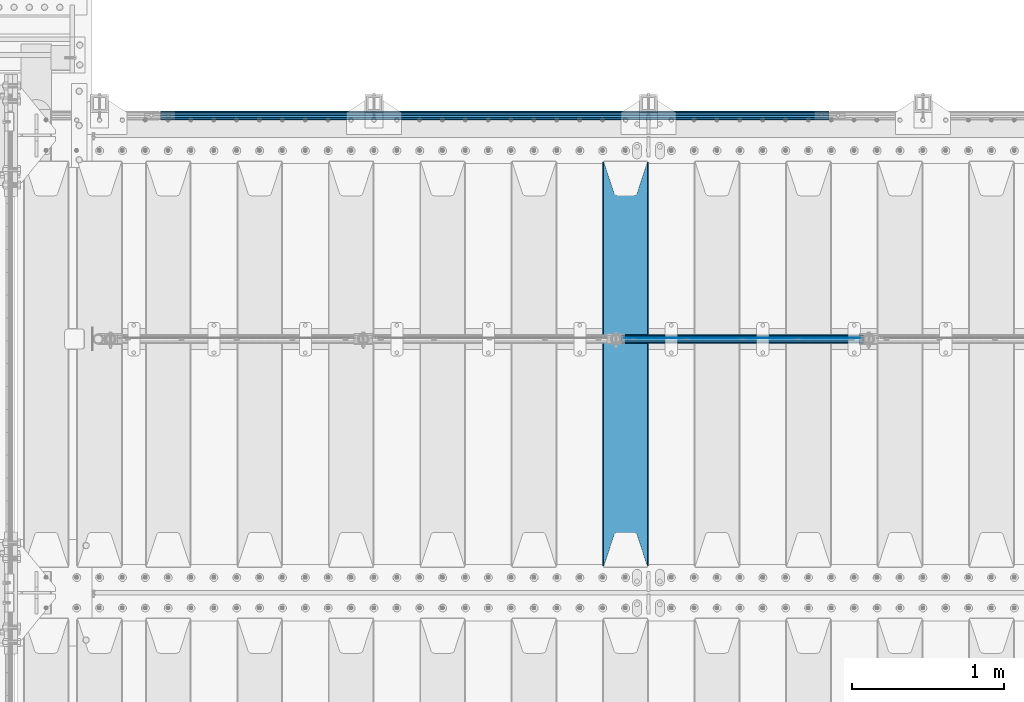
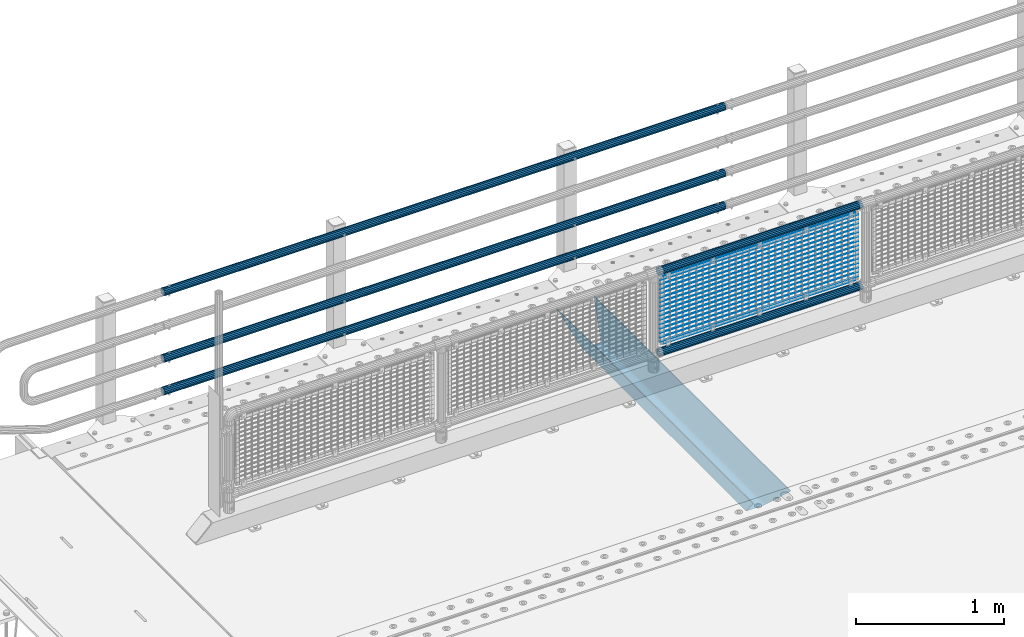
# One storey, part 111 of 219: 23 beams.
"""IFC2X3 building model written with IfcOpenShell, lengths in millimetres."""

import ifcopenshell
import ifcopenshell.guid

model = None  # the IFC model being written
_history = None  # IfcOwnerHistory: only IFC2X3 demands one
_inside = {}  # id of a spatial element -> (the spatial element, [elements in it])
_under = {}  # id of a project, library or spatial element -> (it, [spatial elements below it])
_declared = {}  # id of a project -> (the project, [libraries it declares])
_typed = {}  # id of a type object -> (the type object, [elements of that type])
_made_of = {}  # id of a material, layer set ... -> (it, [elements and type objects made of it])


def new_model(schema):
    """Start an empty IFC model of exactly this schema.

    Asked for "IFC4X3", IfcOpenShell would pick the latest addendum, in which some entities
    have other attributes; the version numbers below select the first issue.
    IFC2X3 requires an IfcOwnerHistory on every rooted entity: one is made here for all.
    """
    global model, _history
    if schema == "IFC4X3":
        model = ifcopenshell.file(schema_version=(4, 3, 0, 0))
    else:
        model = ifcopenshell.file(schema=schema)
    _inside.clear()
    _under.clear()
    _declared.clear()
    _typed.clear()
    _made_of.clear()
    _history = None
    if model.schema == "IFC2X3":
        org = make("IfcOrganization", Name="unknown")
        user = make(
            "IfcPersonAndOrganization",
            ThePerson=make("IfcPerson", FamilyName="unknown"),
            TheOrganization=org,
        )
        app = make(
            "IfcApplication",
            ApplicationDeveloper=org,
            Version="unknown",
            ApplicationFullName="unknown",
            ApplicationIdentifier="unknown",
        )
        _history = make(
            "IfcOwnerHistory",
            OwningUser=user,
            OwningApplication=app,
            ChangeAction="ADDED",
            CreationDate=0,
        )
    return model


def make(cls, **values):
    """One entity of the class cls with the attributes given. An attribute that is None is left unset."""
    return model.create_entity(
        cls, **{name: value for name, value in values.items() if value is not None}
    )


def rooted(cls, **values):
    """An entity with a GlobalId (a new one), such as an element, a storey or a relation."""
    return make(cls, GlobalId=ifcopenshell.guid.new(), OwnerHistory=_history, **values)


def si_unit(unit_type, name, prefix=None):
    """IfcSIUnit, for example si_unit("LENGTHUNIT", "METRE", prefix="MILLI")."""
    return make("IfcSIUnit", UnitType=unit_type, Prefix=prefix, Name=name)


def assignment(units):
    """IfcUnitAssignment: the units of a project."""
    return None if units is None else make("IfcUnitAssignment", Units=units)


def point(xyz):
    """IfcCartesianPoint."""
    return None if xyz is None else make("IfcCartesianPoint", Coordinates=xyz)


def direction(xyz):
    """IfcDirection."""
    return None if xyz is None else make("IfcDirection", DirectionRatios=xyz)


def frame(location, z_axis=None, x_axis=None):
    """IfcAxis2Placement3D, a coordinate frame: its origin and axes. An axis left out is left unset."""
    return make(
        "IfcAxis2Placement3D",
        Location=point(location),
        Axis=direction(z_axis),
        RefDirection=direction(x_axis),
    )


def origin_with_axes():
    """The frame at (0, 0, 0) with the z axis (0, 0, 1) and the x axis (1, 0, 0) written out."""
    return frame((0.0, 0.0, 0.0), z_axis=(0.0, 0.0, 1.0), x_axis=(1.0, 0.0, 0.0))


def place(relative_to, where):
    """IfcLocalPlacement: puts the frame where relative to a parent placement (None: the world)."""
    return make(
        "IfcLocalPlacement", PlacementRelTo=relative_to, RelativePlacement=where
    )


def context(
    kind, dimensions, precision=None, world=None, true_north=None, identifier=None
):
    """IfcGeometricRepresentationContext, for example the 3D "Model" context."""
    return make(
        "IfcGeometricRepresentationContext",
        ContextIdentifier=identifier,
        ContextType=kind,
        CoordinateSpaceDimension=dimensions,
        Precision=precision,
        WorldCoordinateSystem=world,
        TrueNorth=true_north,
    )


def subcontext(parent, identifier, kind, view, scale=None):
    """IfcGeometricRepresentationSubContext, for example "Body" below "Model"."""
    return make(
        "IfcGeometricRepresentationSubContext",
        ContextIdentifier=identifier,
        ContextType=kind,
        ParentContext=parent,
        TargetScale=scale,
        TargetView=view,
    )


def project(units=None, contexts=None):
    """IfcProject with its units and contexts."""
    return rooted(
        "IfcProject",
        Name="project",
        RepresentationContexts=contexts,
        UnitsInContext=assignment(units),
    )


def spatial(cls, under=None, at=None, **own):
    """A site, building, storey or space (cls), placed at a placement, below another one or the project."""
    s = rooted(cls, ObjectPlacement=at, **own)
    if under is not None:
        _under.setdefault(under.id(), (under, []))[1].append(s)
    return s


def faces_of(points, faces, orient=None, outer=None):
    """IfcFace entities. A face is a list of loops; a loop is a list of indices into points, from 0.

    orient and outer hold one flag for each loop. By default every Orientation is true, the
    first loop of a face is its IfcFaceOuterBound and the others are IfcFaceBound.
    """
    made = []
    for i, loops in enumerate(faces):
        bounds = []
        for j, loop in enumerate(loops):
            is_outer = j == 0 if outer is None else outer[i][j]
            bounds.append(
                make(
                    "IfcFaceOuterBound" if is_outer else "IfcFaceBound",
                    Bound=make("IfcPolyLoop", Polygon=[points[k] for k in loop]),
                    Orientation=True if orient is None else orient[i][j],
                )
            )
        made.append(make("IfcFace", Bounds=bounds))
    return made


def faceted_brep(points, faces, orient=None, outer=None, voids=None):
    """IfcFacetedBrep: a solid bounded by flat faces; with voids (closed shells), ...WithVoids."""
    shared = [point(p) for p in points]
    hull = make("IfcClosedShell", CfsFaces=faces_of(shared, faces, orient, outer))
    if voids is None:
        return make("IfcFacetedBrep", Outer=hull)
    return make(
        "IfcFacetedBrepWithVoids",
        Outer=hull,
        Voids=[
            make(cls, CfsFaces=faces_of(shared, fs, o, b)) for cls, fs, o, b in voids
        ],
    )


def shape(context_of_items, identifier, shape_type, items):
    """IfcShapeRepresentation: the items that make up one representation, for example the "Body"."""
    return make(
        "IfcShapeRepresentation",
        ContextOfItems=context_of_items,
        RepresentationIdentifier=identifier,
        RepresentationType=shape_type,
        Items=items,
    )


def material(Name=None, Category=None):
    """IfcMaterial."""
    return make("IfcMaterial", Name=Name, Category=Category)


def made_of(thing, what):
    """Note that an element or type object is made of a material, layer set ...; save() writes the relation."""
    if what is not None:
        _made_of.setdefault(what.id(), (what, []))[1].append(thing)
    return thing


def type_object(cls, material=None, **own):
    """A type object (cls), such as IfcWallType, which elements share."""
    return made_of(rooted(cls, **own), material)


def element(
    cls,
    number,
    at=None,
    inside=None,
    cuts=None,
    type_object=None,
    material=None,
    context=None,
    identifier="Body",
    shape_type=None,
    held_by="IfcProductDefinitionShape",
    body=None,
    shapes=None,
    **own,
):
    """One element of the class cls, such as IfcWall. Its Tag is "e" and its number.

    at: its placement. inside: the storey or other place that contains it. cuts: it is an
    opening in that element (IfcRelVoidsElement). A single representation is given by context,
    identifier, shape_type and body (its items); several are given by shapes. held_by: the class
    of the entity that holds the representations. save() writes the other relations.
    """
    e = rooted(cls, Tag="e%d" % number, ObjectPlacement=at, **own)
    if body is not None:
        shapes = [shape(context, identifier, shape_type, body)]
    if shapes is not None:
        e.Representation = make(held_by, Representations=shapes)
    if inside is not None:
        _inside.setdefault(inside.id(), (inside, []))[1].append(e)
    if cuts is not None:
        rooted(
            "IfcRelVoidsElement", RelatingBuildingElement=cuts, RelatedOpeningElement=e
        )
    if type_object is not None:
        _typed.setdefault(type_object.id(), (type_object, []))[1].append(e)
    return made_of(e, material)


def aggregate(whole, parts):
    """IfcRelAggregates: a whole, such as a stair, and the parts it consists of."""
    return rooted("IfcRelAggregates", RelatingObject=whole, RelatedObjects=parts)


def save(model, path):
    """Write the relations noted so far, then the file.

    IfcRelAggregates (storeys below a building ...), IfcRelContainedInSpatialStructure (elements
    in a storey), IfcRelDefinesByType, IfcRelAssociatesMaterial and IfcRelDeclares: one each for
    every whole, place, type object, material and project.
    """
    for whole, parts in _under.values():
        aggregate(whole, parts)
    for where, things in _inside.values():
        rooted(
            "IfcRelContainedInSpatialStructure",
            RelatedElements=things,
            RelatingStructure=where,
        )
    for kind, things in _typed.values():
        rooted("IfcRelDefinesByType", RelatedObjects=things, RelatingType=kind)
    for what, things in _made_of.values():
        rooted("IfcRelAssociatesMaterial", RelatedObjects=things, RelatingMaterial=what)
    for by, libraries in _declared.values():
        rooted("IfcRelDeclares", RelatingContext=by, RelatedDefinitions=libraries)
    model.write(path)


model = new_model("IFC2X3")

# Units and contexts
model_context = context("Model", 3, precision=1e-05, world=origin_with_axes())
body_context = subcontext(model_context, "Body", "Model", "MODEL_VIEW")
ifc_project = project(units=[si_unit("LENGTHUNIT", "METRE", prefix="MILLI"), si_unit("AREAUNIT", "SQUARE_METRE"), si_unit("VOLUMEUNIT", "CUBIC_METRE"), si_unit("MASSUNIT", "GRAM", prefix="KILO"), si_unit("TIMEUNIT", "SECOND"), si_unit("PLANEANGLEUNIT", "RADIAN"), si_unit("SOLIDANGLEUNIT", "STERADIAN"), si_unit("THERMODYNAMICTEMPERATUREUNIT", "DEGREE_CELSIUS"), si_unit("LUMINOUSINTENSITYUNIT", "LUMEN")], contexts=[model_context])

# Site, building, storey
site_placement = place(None, origin_with_axes())
site = spatial("IfcSite", under=ifc_project, at=site_placement, CompositionType="ELEMENT")
building_placement = place(site_placement, origin_with_axes())
building = spatial("IfcBuilding", under=site, at=building_placement, Name="Standard", CompositionType="ELEMENT")
storey_placement = place(building_placement, origin_with_axes())
storey = spatial("IfcBuildingStorey", under=building, at=storey_placement, Name="Undefined", CompositionType="ELEMENT", Elevation=0.0)

# Beams
ifc_material_1 = material(Name="STEEL/S355N")
beam_type_1 = type_object("IfcBeamType", PredefinedType="NOTDEFINED")
beam_1_placement = place(storey_placement, frame((4000.0, 30175.0, -115.0), z_axis=(0.0, 0.0, 1.0), x_axis=(0.0, 1.0, 0.0)))
element("IfcBeam", 1, at=beam_1_placement, inside=storey, type_object=beam_type_1, material=ifc_material_1, context=body_context, shape_type="Brep", body=[
    faceted_brep([(0.0, 150.0, 115.0), (0.0, 143.690000000001, 115.0), (2650.00000000297, 143.690000000001, 115.0), (2650.00000000297, 150.0, 115.0), (2650.00000000297, 142.0595652184, 110.000000003094), (2650.00000000297, 148.3695652184, 110.000000003094), (2441.90079219209, -80.110360073113, -98.0992078077845), (2437.7588105432, -77.5672621345566, -102.241189456673), (2434.06523489747, -74.4080125315541, -105.934765102404), (2430.9108609509, -70.7102721255742, -109.089139048974), (2428.37322971128, -66.5649389910068, -111.626770288588), (2426.51472138055, -62.0739139532889, -113.485278619323), (2425.38102192092, -57.3475956567672, -114.618978078955), (2424.99999999988, -52.5021667386536, -115.0), (2424.99999999988, 52.5021667386536, -115.0), (2425.38102192092, 57.3475956567672, -114.618978078955), (2426.51472138055, 62.0739139532889, -113.485278619323), (2428.37322971128, 66.5649389910068, -111.626770288588), (2430.9108609509, 70.7102721255742, -109.089139048974), (2434.06523489747, 74.4080125315541, -105.934765102404), (2437.7588105432, 77.5672621345566, -102.241189456673), (2441.90079219209, 80.110360073113, -98.0992078077846), (2446.38936140512, 81.9747917625791, -93.6106385947584), (2448.2494850041, 76.2713538057269, -91.7505149957729), (2444.62967112263, 74.7677798626082, -95.3703288772456), (2441.28936334127, 72.7168944282894, -98.710636658607), (2438.31067330439, 70.1691124903828, -101.689326695487), (2435.76682334748, 67.1870637758839, -104.233176652398), (2433.72034654134, 63.8440531834913, -106.279653458539), (2432.22154950042, 60.2222587982342, -107.778450499454), (2431.30727574265, 56.4107117849107, -108.692724257221), (2430.99999999987, 52.5031078186894, -109.0), (2430.99999999987, -52.5031078186894, -109.0), (2431.30727574265, -56.4107117849107, -108.692724257221), (2432.22154950042, -60.2222587982342, -107.778450499454), (2433.72034654134, -63.8440531834913, -106.279653458539), (2435.76682334748, -67.1870637758839, -104.233176652398), (2438.31067330439, -70.1691124903828, -101.689326695487), (2441.28936334127, -72.7168944282894, -98.7106366586071), (2444.62967112263, -74.7677798626082, -95.3703288772457), (2448.2494850041, -76.2713538057269, -91.7505149957729), (2650.00000000297, -142.0595652184, 110.000000003094), (2650.00000000297, -148.3695652184, 110.000000003094), (2446.38936140512, -81.9747917625791, -93.6106385947584), (2650.00000000297, -143.690000000001, 115.0), (2650.00000000297, -150.0, 115.0), (0.0, -143.690000000001, 115.0), (0.0, -150.0, 115.0), (0.0, -148.369565218261, 110.000000002667), (203.610638597427, -81.9747917625791, -93.6106385947584), (208.09920781045, -80.110360073113, -98.0992078077845), (212.241189459342, -77.5672621345566, -102.241189456673), (215.93476510507, -74.4080125315541, -105.934765102404), (219.089139051641, -70.7102721255742, -109.089139048974), (221.626770291256, -66.5649389910068, -111.626770288588), (223.485278621989, -62.0739139532889, -113.485278619323), (224.618978081624, -57.3475956567672, -114.618978078955), (225.000000002663, -52.5021667386536, -115.0), (225.000000002663, 52.5021667386536, -115.0), (224.618978081624, 57.3475956567672, -114.618978078955), (223.485278621989, 62.0739139532889, -113.485278619323), (221.626770291256, 66.5649389910068, -111.626770288588), (219.089139051641, 70.7102721255742, -109.089139048974), (215.93476510507, 74.4080125315541, -105.934765102404), (212.241189459342, 77.5672621345566, -102.241189456673), (208.09920781045, 80.110360073113, -98.0992078077846), (203.610638597427, 81.9747917625791, -93.6106385947584), (0.0, 148.369565218261, 110.000000002667), (0.0, 142.059565218262, 110.000000002667), (201.750514998439, 76.2713538057269, -91.7505149957729), (205.370328879915, 74.7677798626082, -95.3703288772456), (208.710636661275, 72.7168944282894, -98.710636658607), (211.689326698157, 70.1691124903828, -101.689326695487), (214.233176655063, 67.1870637758839, -104.233176652398), (216.279653461206, 63.8440531834913, -106.279653458539), (217.778450502123, 60.2222587982342, -107.778450499454), (218.69272425989, 56.4107117849107, -108.692724257221), (219.00000000267, 52.5031078186894, -109.0), (219.00000000267, -52.5031078186894, -109.0), (218.69272425989, -56.4107117849107, -108.692724257221), (217.778450502123, -60.2222587982342, -107.778450499454), (216.279653461206, -63.8440531834913, -106.279653458539), (214.233176655063, -67.1870637758839, -104.233176652398), (211.689326698157, -70.1691124903828, -101.689326695487), (208.710636661275, -72.7168944282894, -98.7106366586071), (205.370328879915, -74.7677798626082, -95.3703288772457), (201.750514998439, -76.2713538057269, -91.7505149957729), (0.0, -142.059565218262, 110.000000002667)], [[[0, 1, 2, 3]], [[3, 2, 4, 5]], [[6, 7, 8, 9, 10, 11, 12, 13, 14, 15, 16, 17, 18, 19, 20, 21, 22, 5, 4, 23, 24, 25, 26, 27, 28, 29, 30, 31, 32, 33, 34, 35, 36, 37, 38, 39, 40, 41, 42, 43]], [[44, 45, 42, 41]], [[46, 47, 45, 44]], [[43, 42, 45, 47, 48, 49]], [[6, 43, 49, 50]], [[7, 6, 50, 51]], [[8, 7, 51, 52]], [[9, 8, 52, 53]], [[10, 9, 53, 54]], [[11, 10, 54, 55]], [[12, 11, 55, 56]], [[13, 12, 56, 57]], [[14, 13, 57, 58]], [[15, 14, 58, 59]], [[16, 15, 59, 60]], [[17, 16, 60, 61]], [[18, 17, 61, 62]], [[19, 18, 62, 63]], [[20, 19, 63, 64]], [[21, 20, 64, 65]], [[22, 21, 65, 66]], [[0, 3, 5, 22, 66, 67]], [[1, 0, 67, 68]], [[23, 4, 2, 1, 68, 69]], [[24, 23, 69, 70]], [[25, 24, 70, 71]], [[26, 25, 71, 72]], [[27, 26, 72, 73]], [[28, 27, 73, 74]], [[29, 28, 74, 75]], [[30, 29, 75, 76]], [[31, 30, 76, 77]], [[32, 31, 77, 78]], [[33, 32, 78, 79]], [[34, 33, 79, 80]], [[35, 34, 80, 81]], [[36, 35, 81, 82]], [[37, 36, 82, 83]], [[38, 37, 83, 84]], [[39, 38, 84, 85]], [[40, 39, 85, 86]], [[46, 44, 41, 40, 86, 87]], [[47, 46, 87, 48]], [[86, 85, 84, 83, 82, 81, 80, 79, 78, 77, 76, 75, 74, 73, 72, 71, 70, 69, 68, 67, 66, 65, 64, 63, 62, 61, 60, 59, 58, 57, 56, 55, 54, 53, 52, 51, 50, 49, 48, 87]]]),
])
ifc_material_2 = material(Name="Misc_Undefined")
beam_type_2 = type_object("IfcBeamType", Name="D3", PredefinedType="NOTDEFINED")
for number, where, z_axis, x_axis in (
    (2, (3992.0, 31670.5, 851.597), (0.0, 0.0, 1.0), (1.0, 0.0, 0.0)),
    (3, (3992.0, 31670.5, 669.452), (0.0, 0.0, 1.0), (1.0, 0.0, 0.0)),
    (4, (3992.0, 31670.5, 523.736), (0.0, 0.0, 1.0), (1.0, 0.0, 0.0)),
    (5, (3992.0, 31670.5, 487.307), (0.0, 0.0, 1.0), (1.0, 0.0, 0.0)),
    (6, (3992.0, 31670.5, 705.881), (0.0, 0.0, 1.0), (1.0, 0.0, 0.0)),
    (7, (3992.0, 31670.5, 596.594), (0.0, 0.0, 1.0), (1.0, 0.0, 0.0)),
    (8, (3992.0, 31670.5, 450.878), (0.0, 0.0, 1.0), (1.0, 0.0, 0.0)),
    (9, (3992.0, 31670.5, 815.168), (0.0, 0.0, 1.0), (1.0, 0.0, 0.0)),
    (10, (3992.0, 31670.5, 888.026), (0.0, 0.0, 1.0), (1.0, 0.0, 0.0)),
    (11, (3992.0, 31670.5, 778.739), (0.0, 0.0, 1.0), (1.0, 0.0, 0.0)),
    (12, (3992.0, 31670.5, 742.31), (0.0, 0.0, 1.0), (1.0, 0.0, 0.0)),
    (13, (3992.0, 31670.5, 633.023), (0.0, 0.0, 1.0), (1.0, 0.0, 0.0)),
    (14, (3992.0, 31670.5, 560.165), (0.0, 0.0, 1.0), (1.0, 0.0, 0.0)),
    (15, (3992.0, 31670.5, 414.449), (0.0, 0.0, 1.0), (1.0, 0.0, 0.0)),
):
    element("IfcBeam", number, at=place(storey_placement, frame(where, z_axis=z_axis, x_axis=x_axis)), inside=storey, type_object=beam_type_2, material=ifc_material_2, ObjectType="D3", context=body_context, shape_type="Brep", body=[
        faceted_brep([(0.0, -1.5, -5.6843418860808e-14), (0.0, -0.75, -1.29903810567669), (1548.0, -0.75, -1.29903810567669), (1548.0, -1.5, 0.0), (0.0, 0.75, -1.29903810567669), (1548.0, 0.75, -1.29903810567669), (0.0, 1.5, -5.6843418860808e-14), (1548.0, 1.5, 0.0), (0.0, 0.75, 1.29903810567669), (1548.0, 0.75, 1.29903810567669), (0.0, -0.75, 1.29903810567669), (1548.0, -0.75, 1.29903810567669)], [[[0, 1, 2, 3]], [[1, 4, 5, 2]], [[4, 6, 7, 5]], [[6, 8, 9, 7]], [[8, 10, 11, 9]], [[10, 0, 3, 11]], [[5, 7, 9, 11, 3, 2]], [[10, 8, 6, 4, 1, 0]]]),
    ])
beam_2_placement = place(storey_placement, frame((4017.0, 31670.5, 353.02), z_axis=(0.0, 0.0, 1.0), x_axis=(1.0, 0.0, 0.0)))
element("IfcBeam", 16, at=beam_2_placement, inside=storey, type_object=beam_type_2, material=ifc_material_2, ObjectType="D3", context=body_context, shape_type="Brep", body=[
    faceted_brep([(0.0, -1.5, -5.6843418860808e-14), (0.0, -0.75, -1.29903810567669), (1498.0, -0.75, -1.29903810567669), (1498.0, -1.5, 0.0), (0.0, 0.75, -1.29903810567669), (1498.0, 0.75, -1.29903810567663), (0.0, 1.5, -5.6843418860808e-14), (1498.0, 1.5, 0.0), (0.0, 0.75, 1.29903810567669), (1498.0, 0.75, 1.29903810567669), (0.0, -0.75, 1.29903810567669), (1498.0, -0.75, 1.29903810567669)], [[[0, 1, 2, 3]], [[1, 4, 5, 2]], [[4, 6, 7, 5]], [[6, 8, 9, 7]], [[8, 10, 11, 9]], [[10, 0, 3, 11]], [[5, 7, 9, 11, 3, 2]], [[10, 8, 6, 4, 1, 0]]]),
])
beam_3_placement = place(storey_placement, frame((3992.0, 31670.5, 378.02), z_axis=(0.0, 0.0, 1.0), x_axis=(1.0, 0.0, 0.0)))
element("IfcBeam", 17, at=beam_3_placement, inside=storey, type_object=beam_type_2, material=ifc_material_2, ObjectType="D3", context=body_context, shape_type="Brep", body=[
    faceted_brep([(0.0, -1.5, -5.6843418860808e-14), (0.0, -0.75, -1.29903810567669), (1548.0, -0.75, -1.29903810567669), (1548.0, -1.5, 0.0), (0.0, 0.75, -1.29903810567669), (1548.0, 0.75, -1.29903810567669), (0.0, 1.5, -5.6843418860808e-14), (1548.0, 1.5, 0.0), (0.0, 0.75, 1.29903810567669), (1548.0, 0.75, 1.29903810567669), (0.0, -0.75, 1.29903810567669), (1548.0, -0.75, 1.29903810567669)], [[[0, 1, 2, 3]], [[1, 4, 5, 2]], [[4, 6, 7, 5]], [[6, 8, 9, 7]], [[8, 10, 11, 9]], [[10, 0, 3, 11]], [[5, 7, 9, 11, 3, 2]], [[10, 8, 6, 4, 1, 0]]]),
])
beam_4_placement = place(storey_placement, frame((4017.0, 31670.5, 913.02), z_axis=(0.0, 0.0, 1.0), x_axis=(1.0, 0.0, 0.0)))
element("IfcBeam", 18, at=beam_4_placement, inside=storey, type_object=beam_type_2, material=ifc_material_2, ObjectType="D3", context=body_context, shape_type="Brep", body=[
    faceted_brep([(0.0, -1.5, -5.6843418860808e-14), (0.0, -0.75, -1.29903810567669), (1498.0, -0.75, -1.29903810567669), (1498.0, -1.5, 0.0), (0.0, 0.75, -1.29903810567669), (1498.0, 0.75, -1.29903810567663), (0.0, 1.5, -5.6843418860808e-14), (1498.0, 1.5, 0.0), (0.0, 0.75, 1.29903810567669), (1498.0, 0.75, 1.29903810567669), (0.0, -0.75, 1.29903810567669), (1498.0, -0.75, 1.29903810567669)], [[[0, 1, 2, 3]], [[1, 4, 5, 2]], [[4, 6, 7, 5]], [[6, 8, 9, 7]], [[8, 10, 11, 9]], [[10, 0, 3, 11]], [[5, 7, 9, 11, 3, 2]], [[10, 8, 6, 4, 1, 0]]]),
])
ifc_material_3 = material()
beam_type_3 = type_object("IfcBeamType", PredefinedType="NOTDEFINED")
beam_5_placement = place(storey_placement, frame((3971.85, 31664.5, 969.85), z_axis=(0.0, 0.0, 1.0), x_axis=(1.0, 0.0, 0.0)))
element("IfcBeam", 19, at=beam_5_placement, inside=storey, type_object=beam_type_3, material=ifc_material_3, context=body_context, shape_type="Brep", body=[
    faceted_brep([(0.0, -25.3499999999985, 0.0), (0.0, -23.4203461491597, 9.70102501045585), (1588.0, -23.4203461491597, 9.70102501045506), (1588.0, -25.3499999999985, 0.0), (0.0, -17.9251569030785, 17.9251569030785), (1588.0, -17.9251569030785, 17.925156903079), (0.0, -9.70102501045403, 23.4203461491616), (1588.0, -9.70102501045403, 23.4203461491611), (0.0, 0.0, 25.3500000000004), (1588.0, 0.0, 25.35), (0.0, 9.70102501045403, 23.4203461491616), (1588.0, 9.70102501045403, 23.4203461491611), (0.0, 17.9251569030785, 17.9251569030785), (1588.0, 17.9251569030785, 17.925156903079), (0.0, 23.4203461491597, 9.70102501045585), (1588.0, 23.4203461491597, 9.70102501045506), (0.0, 25.3499999999985, 0.0), (1588.0, 25.3499999999985, 0.0), (0.0, 23.4203461491597, -9.70102501045585), (1588.0, 23.4203461491597, -9.70102501045506), (0.0, 17.9251569030785, -17.9251569030785), (1588.0, 17.9251569030785, -17.925156903079), (0.0, 9.70102501045403, -23.4203461491616), (1588.0, 9.70102501045403, -23.4203461491611), (0.0, 0.0, -25.3500000000004), (1588.0, 0.0, -25.35), (0.0, -9.70102501045403, -23.4203461491616), (1588.0, -9.70102501045403, -23.4203461491611), (0.0, -17.9251569030785, -17.9251569030785), (1588.0, -17.9251569030785, -17.925156903079), (0.0, -23.4203461491597, -9.70102501045585), (1588.0, -23.4203461491597, -9.70102501045506), (0.0, -30.1500000000015, 0.0), (0.0, -27.8549679052157, -11.5379054858076), (1588.0, -27.8549679052157, -11.5379054858075), (1588.0, -30.1500000000015, 0.0), (0.0, -21.3192694527752, -21.3192694527752), (1588.0, -21.3192694527752, -21.3192694527744), (0.0, -11.5379054858058, -27.8549679052157), (1588.0, -11.5379054858058, -27.8549679052153), (0.0, 0.0, -30.1499999999996), (1588.0, 0.0, -30.15), (0.0, 11.5379054858058, -27.8549679052157), (1588.0, 11.5379054858058, -27.8549679052153), (0.0, 21.3192694527752, -21.3192694527752), (1588.0, 21.3192694527752, -21.3192694527744), (0.0, 27.8549679052157, -11.5379054858076), (1588.0, 27.8549679052157, -11.5379054858074), (0.0, 30.1500000000015, 0.0), (1588.0, 30.1500000000015, 0.0), (0.0, 27.8549679052157, 11.5379054858076), (1588.0, 27.8549679052157, 11.5379054858074), (0.0, 21.3192694527752, 21.3192694527752), (1588.0, 21.3192694527752, 21.3192694527744), (0.0, 11.5379054858058, 27.8549679052157), (1588.0, 11.5379054858058, 27.8549679052153), (0.0, 0.0, 30.1499999999996), (1588.0, 0.0, 30.15), (0.0, -11.5379054858058, 27.8549679052157), (1588.0, -11.5379054858058, 27.8549679052153), (0.0, -21.3192694527752, 21.3192694527752), (1588.0, -21.3192694527752, 21.3192694527744), (0.0, -27.8549679052157, 11.5379054858076), (1588.0, -27.8549679052157, 11.5379054858074)], [[[0, 1, 2, 3]], [[1, 4, 5, 2]], [[4, 6, 7, 5]], [[6, 8, 9, 7]], [[8, 10, 11, 9]], [[10, 12, 13, 11]], [[12, 14, 15, 13]], [[14, 16, 17, 15]], [[16, 18, 19, 17]], [[18, 20, 21, 19]], [[20, 22, 23, 21]], [[22, 24, 25, 23]], [[24, 26, 27, 25]], [[26, 28, 29, 27]], [[28, 30, 31, 29]], [[30, 0, 3, 31]], [[32, 33, 34, 35]], [[33, 36, 37, 34]], [[36, 38, 39, 37]], [[38, 40, 41, 39]], [[40, 42, 43, 41]], [[42, 44, 45, 43]], [[44, 46, 47, 45]], [[46, 48, 49, 47]], [[48, 50, 51, 49]], [[50, 52, 53, 51]], [[52, 54, 55, 53]], [[54, 56, 57, 55]], [[56, 58, 59, 57]], [[58, 60, 61, 59]], [[60, 62, 63, 61]], [[62, 32, 35, 63]], [[37, 39, 41, 43, 45, 47, 49, 51, 53, 55, 57, 59, 61, 63, 35, 34], [5, 7, 9, 11, 13, 15, 17, 19, 21, 23, 25, 27, 29, 31, 3, 2]], [[62, 60, 58, 56, 54, 52, 50, 48, 46, 44, 42, 40, 38, 36, 33, 32], [30, 28, 26, 24, 22, 20, 18, 16, 14, 12, 10, 8, 6, 4, 1, 0]]]),
])
beam_6_placement = place(storey_placement, frame((3971.85000000001, 31664.5, 298.170000000001), z_axis=(0.0, 0.0, 1.0), x_axis=(1.0, 0.0, 0.0)))
element("IfcBeam", 20, at=beam_6_placement, inside=storey, type_object=beam_type_3, material=ifc_material_3, context=body_context, shape_type="Brep", body=[
    faceted_brep([(0.0, -25.3499999999985, 0.0), (0.0, -23.4203461491597, 9.70102501045585), (1588.0, -23.4203461491597, 9.70102501045506), (1588.0, -25.3499999999985, 0.0), (0.0, -17.9251569030785, 17.9251569030785), (1588.0, -17.9251569030785, 17.925156903079), (0.0, -9.70102501045403, 23.4203461491616), (1588.0, -9.70102501045403, 23.4203461491611), (0.0, 0.0, 25.3500000000004), (1588.0, 0.0, 25.35), (0.0, 9.70102501045403, 23.4203461491616), (1588.0, 9.70102501045403, 23.4203461491611), (0.0, 17.9251569030785, 17.9251569030785), (1588.0, 17.9251569030785, 17.925156903079), (0.0, 23.4203461491597, 9.70102501045585), (1588.0, 23.4203461491597, 9.70102501045506), (0.0, 25.3499999999985, 0.0), (1588.0, 25.3499999999985, 0.0), (0.0, 23.4203461491597, -9.70102501045585), (1588.0, 23.4203461491597, -9.70102501045506), (0.0, 17.9251569030785, -17.9251569030785), (1588.0, 17.9251569030785, -17.925156903079), (0.0, 9.70102501045403, -23.4203461491616), (1588.0, 9.70102501045403, -23.4203461491611), (0.0, 0.0, -25.3500000000004), (1588.0, 0.0, -25.35), (0.0, -9.70102501045403, -23.4203461491616), (1588.0, -9.70102501045403, -23.4203461491611), (0.0, -17.9251569030785, -17.9251569030785), (1588.0, -17.9251569030785, -17.925156903079), (0.0, -23.4203461491597, -9.70102501045585), (1588.0, -23.4203461491597, -9.70102501045506), (0.0, -30.1500000000015, 0.0), (0.0, -27.8549679052157, -11.5379054858076), (1588.0, -27.8549679052157, -11.5379054858075), (1588.0, -30.1500000000015, 0.0), (0.0, -21.3192694527752, -21.3192694527752), (1588.0, -21.3192694527752, -21.3192694527744), (0.0, -11.5379054858058, -27.8549679052157), (1588.0, -11.5379054858058, -27.8549679052153), (0.0, 0.0, -30.1499999999996), (1588.0, 0.0, -30.15), (0.0, 11.5379054858058, -27.8549679052157), (1588.0, 11.5379054858058, -27.8549679052153), (0.0, 21.3192694527752, -21.3192694527752), (1588.0, 21.3192694527752, -21.3192694527744), (0.0, 27.8549679052157, -11.5379054858076), (1588.0, 27.8549679052157, -11.5379054858074), (0.0, 30.1500000000015, 0.0), (1588.0, 30.1500000000015, 0.0), (0.0, 27.8549679052157, 11.5379054858076), (1588.0, 27.8549679052157, 11.5379054858074), (0.0, 21.3192694527752, 21.3192694527752), (1588.0, 21.3192694527752, 21.3192694527744), (0.0, 11.5379054858058, 27.8549679052157), (1588.0, 11.5379054858058, 27.8549679052153), (0.0, 0.0, 30.1499999999996), (1588.0, 0.0, 30.15), (0.0, -11.5379054858058, 27.8549679052157), (1588.0, -11.5379054858058, 27.8549679052153), (0.0, -21.3192694527752, 21.3192694527752), (1588.0, -21.3192694527752, 21.3192694527744), (0.0, -27.8549679052157, 11.5379054858076), (1588.0, -27.8549679052157, 11.5379054858074)], [[[0, 1, 2, 3]], [[1, 4, 5, 2]], [[4, 6, 7, 5]], [[6, 8, 9, 7]], [[8, 10, 11, 9]], [[10, 12, 13, 11]], [[12, 14, 15, 13]], [[14, 16, 17, 15]], [[16, 18, 19, 17]], [[18, 20, 21, 19]], [[20, 22, 23, 21]], [[22, 24, 25, 23]], [[24, 26, 27, 25]], [[26, 28, 29, 27]], [[28, 30, 31, 29]], [[30, 0, 3, 31]], [[32, 33, 34, 35]], [[33, 36, 37, 34]], [[36, 38, 39, 37]], [[38, 40, 41, 39]], [[40, 42, 43, 41]], [[42, 44, 45, 43]], [[44, 46, 47, 45]], [[46, 48, 49, 47]], [[48, 50, 51, 49]], [[50, 52, 53, 51]], [[52, 54, 55, 53]], [[54, 56, 57, 55]], [[56, 58, 59, 57]], [[58, 60, 61, 59]], [[60, 62, 63, 61]], [[62, 32, 35, 63]], [[37, 39, 41, 43, 45, 47, 49, 51, 53, 55, 57, 59, 61, 63, 35, 34], [5, 7, 9, 11, 13, 15, 17, 19, 21, 23, 25, 27, 29, 31, 3, 2]], [[62, 60, 58, 56, 54, 52, 50, 48, 46, 44, 42, 40, 38, 36, 33, 32], [30, 28, 26, 24, 22, 20, 18, 16, 14, 12, 10, 8, 6, 4, 1, 0]]]),
])
beam_type_4 = type_object("IfcBeamType", PredefinedType="NOTDEFINED")
beam_7_placement = place(storey_placement, frame((5333.99999999987, 33129.8500000001, 149.849999999748), z_axis=(0.0, 0.0, -1.0), x_axis=(-1.0, 0.0, 0.0)))
element("IfcBeam", 21, at=beam_7_placement, inside=storey, type_object=beam_type_4, material=ifc_material_3, context=body_context, shape_type="Brep", body=[
    faceted_brep([(0.0, -26.5500000000029, 0.0), (0.0, -24.5290015881765, 10.1602451292931), (4384.00249699992, -24.5290015881765, 10.1602451292931), (4384.00249699992, -26.5500000000029, 0.0), (0.0, -18.7736850405054, 18.7736850405028), (4384.00249699992, -18.7736850405054, 18.7736850405028), (0.0, -10.1602451292929, 24.5290015881747), (4384.00249699992, -10.1602451292929, 24.5290015881747), (0.0, 0.0, 26.55), (4384.00249699992, 0.0, 26.55), (0.0, 10.1602451292929, 24.5290015881747), (4384.00249699992, 10.1602451292929, 24.5290015881747), (0.0, 18.7736850405054, 18.7736850405028), (4384.00249699992, 18.7736850405054, 18.7736850405028), (0.0, 24.5290015881765, 10.1602451292931), (4384.00249699992, 24.5290015881765, 10.1602451292931), (0.0, 26.5500000000029, 0.0), (4384.00249699992, 26.5500000000029, 0.0), (0.0, 24.5290015881765, -10.1602451292931), (4384.00249699992, 24.5290015881765, -10.1602451292931), (0.0, 18.7736850405054, -18.7736850405028), (4384.00249699992, 18.7736850405054, -18.7736850405028), (0.0, 10.1602451292929, -24.5290015881747), (4384.00249699992, 10.1602451292929, -24.5290015881747), (0.0, 0.0, -26.55), (4384.00249699992, 0.0, -26.55), (0.0, -10.1602451292929, -24.5290015881747), (4384.00249699992, -10.1602451292929, -24.5290015881747), (0.0, -18.7736850405054, -18.7736850405028), (4384.00249699992, -18.7736850405054, -18.7736850405028), (0.0, -24.5290015881765, -10.1602451292931), (4384.00249699992, -24.5290015881765, -10.1602451292931), (0.0, -30.1500000000015, 0.0), (0.0, -27.8549679052157, -11.5379054858076), (4384.00249699992, -27.8549679052157, -11.5379054858075), (4384.00249699992, -30.1500000000015, 0.0), (0.0, -21.3192694527752, -21.3192694527752), (4384.00249699992, -21.3192694527752, -21.3192694527744), (0.0, -11.5379054858058, -27.8549679052157), (4384.00249699992, -11.5379054858058, -27.8549679052153), (0.0, 0.0, -30.1499999999996), (4384.00249699992, 0.0, -30.15), (0.0, 11.5379054858058, -27.8549679052157), (4384.00249699992, 11.5379054858058, -27.8549679052153), (0.0, 21.3192694527752, -21.3192694527752), (4384.00249699992, 21.3192694527752, -21.3192694527744), (0.0, 27.8549679052157, -11.5379054858076), (4384.00249699992, 27.8549679052157, -11.5379054858074), (0.0, 30.1500000000015, 0.0), (4384.00249699992, 30.1500000000015, 0.0), (0.0, 27.8549679052157, 11.5379054858076), (4384.00249699992, 27.8549679052157, 11.5379054858075), (0.0, 21.3192694527752, 21.3192694527752), (4384.00249699992, 21.3192694527752, 21.3192694527744), (0.0, 11.5379054858058, 27.8549679052157), (4384.00249699992, 11.5379054858058, 27.8549679052153), (0.0, 0.0, 30.1499999999996), (4384.00249699992, 0.0, 30.15), (0.0, -11.5379054858058, 27.8549679052157), (4384.00249699992, -11.5379054858058, 27.8549679052153), (0.0, -21.3192694527752, 21.3192694527752), (4384.00249699992, -21.3192694527752, 21.3192694527744), (0.0, -27.8549679052157, 11.5379054858076), (4384.00249699992, -27.8549679052157, 11.5379054858075)], [[[0, 1, 2, 3]], [[1, 4, 5, 2]], [[4, 6, 7, 5]], [[6, 8, 9, 7]], [[8, 10, 11, 9]], [[10, 12, 13, 11]], [[12, 14, 15, 13]], [[14, 16, 17, 15]], [[16, 18, 19, 17]], [[18, 20, 21, 19]], [[20, 22, 23, 21]], [[22, 24, 25, 23]], [[24, 26, 27, 25]], [[26, 28, 29, 27]], [[28, 30, 31, 29]], [[30, 0, 3, 31]], [[32, 33, 34, 35]], [[33, 36, 37, 34]], [[36, 38, 39, 37]], [[38, 40, 41, 39]], [[40, 42, 43, 41]], [[42, 44, 45, 43]], [[44, 46, 47, 45]], [[46, 48, 49, 47]], [[48, 50, 51, 49]], [[50, 52, 53, 51]], [[52, 54, 55, 53]], [[54, 56, 57, 55]], [[56, 58, 59, 57]], [[58, 60, 61, 59]], [[60, 62, 63, 61]], [[62, 32, 35, 63]], [[37, 39, 41, 43, 45, 47, 49, 51, 53, 55, 57, 59, 61, 63, 35, 34], [5, 7, 9, 11, 13, 15, 17, 19, 21, 23, 25, 27, 29, 31, 3, 2]], [[62, 60, 58, 56, 54, 52, 50, 48, 46, 44, 42, 40, 38, 36, 33, 32], [30, 28, 26, 24, 22, 20, 18, 16, 14, 12, 10, 8, 6, 4, 1, 0]]]),
])
beam_8_placement = place(storey_placement, frame((5333.99999999987, 33129.8500000001, 420.149999999748), z_axis=(0.0, 0.0, -1.0), x_axis=(-1.0, 0.0, 0.0)))
element("IfcBeam", 22, at=beam_8_placement, inside=storey, type_object=beam_type_4, material=ifc_material_3, context=body_context, shape_type="Brep", body=[
    faceted_brep([(0.0, -26.5500000000029, 0.0), (0.0, -24.5290015881765, 10.1602451292931), (4384.00249699992, -24.5290015881765, 10.1602451292931), (4384.00249699992, -26.5500000000029, 0.0), (0.0, -18.7736850405054, 18.7736850405028), (4384.00249699992, -18.7736850405054, 18.7736850405028), (0.0, -10.1602451292929, 24.5290015881747), (4384.00249699992, -10.1602451292929, 24.5290015881747), (0.0, 0.0, 26.55), (4384.00249699992, 0.0, 26.55), (0.0, 10.1602451292929, 24.5290015881747), (4384.00249699992, 10.1602451292929, 24.5290015881747), (0.0, 18.7736850405054, 18.7736850405028), (4384.00249699992, 18.7736850405054, 18.7736850405028), (0.0, 24.5290015881765, 10.1602451292931), (4384.00249699992, 24.5290015881765, 10.1602451292931), (0.0, 26.5500000000029, 0.0), (4384.00249699992, 26.5500000000029, 0.0), (0.0, 24.5290015881765, -10.1602451292931), (4384.00249699992, 24.5290015881765, -10.1602451292931), (0.0, 18.7736850405054, -18.7736850405028), (4384.00249699992, 18.7736850405054, -18.7736850405028), (0.0, 10.1602451292929, -24.5290015881747), (4384.00249699992, 10.1602451292929, -24.5290015881747), (0.0, 0.0, -26.55), (4384.00249699992, 0.0, -26.55), (0.0, -10.1602451292929, -24.5290015881747), (4384.00249699992, -10.1602451292929, -24.5290015881747), (0.0, -18.7736850405054, -18.7736850405028), (4384.00249699992, -18.7736850405054, -18.7736850405028), (0.0, -24.5290015881765, -10.1602451292931), (4384.00249699992, -24.5290015881765, -10.1602451292931), (0.0, -30.1500000000015, 0.0), (0.0, -27.8549679052157, -11.5379054858076), (4384.00249699992, -27.8549679052157, -11.5379054858075), (4384.00249699992, -30.1500000000015, 0.0), (0.0, -21.3192694527752, -21.3192694527752), (4384.00249699992, -21.3192694527752, -21.3192694527744), (0.0, -11.5379054858058, -27.8549679052157), (4384.00249699992, -11.5379054858058, -27.8549679052153), (0.0, 0.0, -30.1499999999996), (4384.00249699992, 0.0, -30.15), (0.0, 11.5379054858058, -27.8549679052157), (4384.00249699992, 11.5379054858058, -27.8549679052153), (0.0, 21.3192694527752, -21.3192694527752), (4384.00249699992, 21.3192694527752, -21.3192694527744), (0.0, 27.8549679052157, -11.5379054858076), (4384.00249699992, 27.8549679052157, -11.5379054858074), (0.0, 30.1500000000015, 0.0), (4384.00249699992, 30.1500000000015, 0.0), (0.0, 27.8549679052157, 11.5379054858076), (4384.00249699992, 27.8549679052157, 11.5379054858075), (0.0, 21.3192694527752, 21.3192694527752), (4384.00249699992, 21.3192694527752, 21.3192694527744), (0.0, 11.5379054858058, 27.8549679052157), (4384.00249699992, 11.5379054858058, 27.8549679052153), (0.0, 0.0, 30.1499999999996), (4384.00249699992, 0.0, 30.15), (0.0, -11.5379054858058, 27.8549679052157), (4384.00249699992, -11.5379054858058, 27.8549679052153), (0.0, -21.3192694527752, 21.3192694527752), (4384.00249699992, -21.3192694527752, 21.3192694527744), (0.0, -27.8549679052157, 11.5379054858076), (4384.00249699992, -27.8549679052157, 11.5379054858075)], [[[0, 1, 2, 3]], [[1, 4, 5, 2]], [[4, 6, 7, 5]], [[6, 8, 9, 7]], [[8, 10, 11, 9]], [[10, 12, 13, 11]], [[12, 14, 15, 13]], [[14, 16, 17, 15]], [[16, 18, 19, 17]], [[18, 20, 21, 19]], [[20, 22, 23, 21]], [[22, 24, 25, 23]], [[24, 26, 27, 25]], [[26, 28, 29, 27]], [[28, 30, 31, 29]], [[30, 0, 3, 31]], [[32, 33, 34, 35]], [[33, 36, 37, 34]], [[36, 38, 39, 37]], [[38, 40, 41, 39]], [[40, 42, 43, 41]], [[42, 44, 45, 43]], [[44, 46, 47, 45]], [[46, 48, 49, 47]], [[48, 50, 51, 49]], [[50, 52, 53, 51]], [[52, 54, 55, 53]], [[54, 56, 57, 55]], [[56, 58, 59, 57]], [[58, 60, 61, 59]], [[60, 62, 63, 61]], [[62, 32, 35, 63]], [[37, 39, 41, 43, 45, 47, 49, 51, 53, 55, 57, 59, 61, 63, 35, 34], [5, 7, 9, 11, 13, 15, 17, 19, 21, 23, 25, 27, 29, 31, 3, 2]], [[62, 60, 58, 56, 54, 52, 50, 48, 46, 44, 42, 40, 38, 36, 33, 32], [30, 28, 26, 24, 22, 20, 18, 16, 14, 12, 10, 8, 6, 4, 1, 0]]]),
])
beam_9_placement = place(storey_placement, frame((5333.99999999987, 33129.8500000001, 969.849999999748), z_axis=(0.0, 0.0, -1.0), x_axis=(-1.0, 0.0, 0.0)))
element("IfcBeam", 23, at=beam_9_placement, inside=storey, type_object=beam_type_4, material=ifc_material_3, context=body_context, shape_type="Brep", body=[
    faceted_brep([(0.0, -26.5500000000029, 0.0), (0.0, -24.5290015881765, 10.1602451292931), (4384.00249699992, -24.5290015881765, 10.1602451292931), (4384.00249699992, -26.5500000000029, 0.0), (0.0, -18.7736850405054, 18.7736850405028), (4384.00249699992, -18.7736850405054, 18.7736850405028), (0.0, -10.1602451292929, 24.5290015881747), (4384.00249699992, -10.1602451292929, 24.5290015881747), (0.0, 0.0, 26.55), (4384.00249699992, 0.0, 26.55), (0.0, 10.1602451292929, 24.5290015881747), (4384.00249699992, 10.1602451292929, 24.5290015881747), (0.0, 18.7736850405054, 18.7736850405028), (4384.00249699992, 18.7736850405054, 18.7736850405028), (0.0, 24.5290015881765, 10.1602451292931), (4384.00249699992, 24.5290015881765, 10.1602451292931), (0.0, 26.5500000000029, 0.0), (4384.00249699992, 26.5500000000029, 0.0), (0.0, 24.5290015881765, -10.1602451292931), (4384.00249699992, 24.5290015881765, -10.1602451292931), (0.0, 18.7736850405054, -18.7736850405028), (4384.00249699992, 18.7736850405054, -18.7736850405028), (0.0, 10.1602451292929, -24.5290015881747), (4384.00249699992, 10.1602451292929, -24.5290015881747), (0.0, 0.0, -26.55), (4384.00249699992, 0.0, -26.55), (0.0, -10.1602451292929, -24.5290015881747), (4384.00249699992, -10.1602451292929, -24.5290015881747), (0.0, -18.7736850405054, -18.7736850405028), (4384.00249699992, -18.7736850405054, -18.7736850405028), (0.0, -24.5290015881765, -10.1602451292931), (4384.00249699992, -24.5290015881765, -10.1602451292931), (0.0, -30.1500000000015, 0.0), (0.0, -27.8549679052157, -11.5379054858076), (4384.00249699992, -27.8549679052157, -11.5379054858075), (4384.00249699992, -30.1500000000015, 0.0), (0.0, -21.3192694527752, -21.3192694527752), (4384.00249699992, -21.3192694527752, -21.3192694527744), (0.0, -11.5379054858058, -27.8549679052157), (4384.00249699992, -11.5379054858058, -27.8549679052153), (0.0, 0.0, -30.1499999999996), (4384.00249699992, 0.0, -30.15), (0.0, 11.5379054858058, -27.8549679052157), (4384.00249699992, 11.5379054858058, -27.8549679052153), (0.0, 21.3192694527752, -21.3192694527752), (4384.00249699992, 21.3192694527752, -21.3192694527744), (0.0, 27.8549679052157, -11.5379054858076), (4384.00249699992, 27.8549679052157, -11.5379054858074), (0.0, 30.1500000000015, 0.0), (4384.00249699992, 30.1500000000015, 0.0), (0.0, 27.8549679052157, 11.5379054858076), (4384.00249699992, 27.8549679052157, 11.5379054858075), (0.0, 21.3192694527752, 21.3192694527752), (4384.00249699992, 21.3192694527752, 21.3192694527744), (0.0, 11.5379054858058, 27.8549679052157), (4384.00249699992, 11.5379054858058, 27.8549679052153), (0.0, 0.0, 30.1499999999996), (4384.00249699992, 0.0, 30.15), (0.0, -11.5379054858058, 27.8549679052157), (4384.00249699992, -11.5379054858058, 27.8549679052153), (0.0, -21.3192694527752, 21.3192694527752), (4384.00249699992, -21.3192694527752, 21.3192694527744), (0.0, -27.8549679052157, 11.5379054858076), (4384.00249699992, -27.8549679052157, 11.5379054858075)], [[[0, 1, 2, 3]], [[1, 4, 5, 2]], [[4, 6, 7, 5]], [[6, 8, 9, 7]], [[8, 10, 11, 9]], [[10, 12, 13, 11]], [[12, 14, 15, 13]], [[14, 16, 17, 15]], [[16, 18, 19, 17]], [[18, 20, 21, 19]], [[20, 22, 23, 21]], [[22, 24, 25, 23]], [[24, 26, 27, 25]], [[26, 28, 29, 27]], [[28, 30, 31, 29]], [[30, 0, 3, 31]], [[32, 33, 34, 35]], [[33, 36, 37, 34]], [[36, 38, 39, 37]], [[38, 40, 41, 39]], [[40, 42, 43, 41]], [[42, 44, 45, 43]], [[44, 46, 47, 45]], [[46, 48, 49, 47]], [[48, 50, 51, 49]], [[50, 52, 53, 51]], [[52, 54, 55, 53]], [[54, 56, 57, 55]], [[56, 58, 59, 57]], [[58, 60, 61, 59]], [[60, 62, 63, 61]], [[62, 32, 35, 63]], [[37, 39, 41, 43, 45, 47, 49, 51, 53, 55, 57, 59, 61, 63, 35, 34], [5, 7, 9, 11, 13, 15, 17, 19, 21, 23, 25, 27, 29, 31, 3, 2]], [[62, 60, 58, 56, 54, 52, 50, 48, 46, 44, 42, 40, 38, 36, 33, 32], [30, 28, 26, 24, 22, 20, 18, 16, 14, 12, 10, 8, 6, 4, 1, 0]]]),
])

save(model, "model.ifc")
